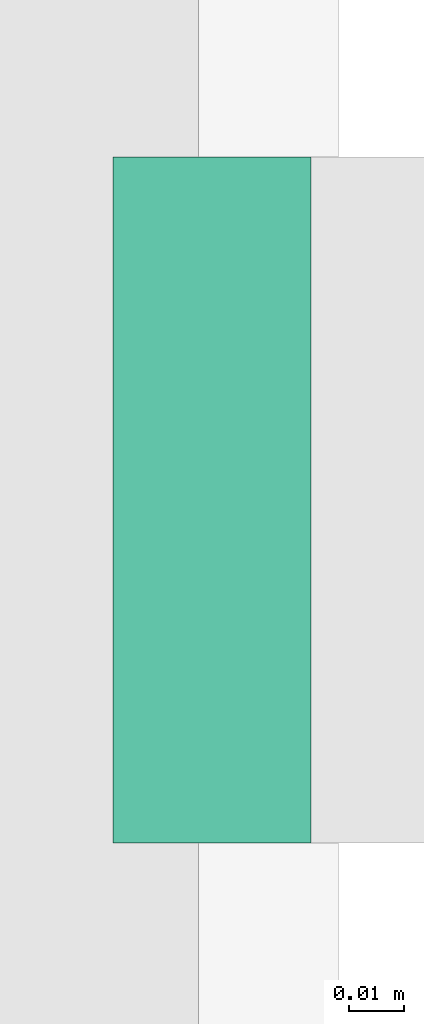
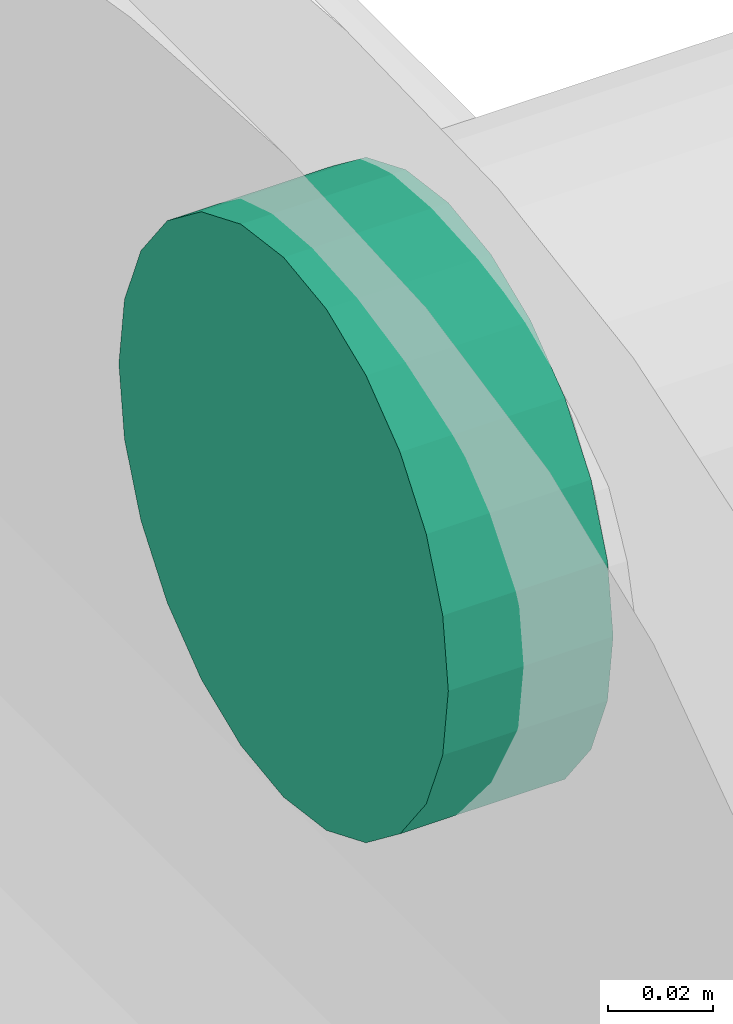
# One storey, part 218 of 337: 1 flow fitting.
"""IFC2X3 building model written with IfcOpenShell, lengths in millimetres."""

from ifc_helpers import new_model, entity, si_unit, converted_unit, derived_unit, direction, frame, origin, place, context, subcontext, project, spatial, faceted_brep, source, transform, mapped, material, type_object, type_shapes, element, save


model = new_model("IFC2X3")

# Units and contexts
model_context = context("Model", 3, precision=0.01, world=origin(), true_north=direction((6.12303176911189e-17, 1.0)))
body_context = subcontext(model_context, "Body", "Model", "MODEL_VIEW")
ifc_project = project(units=[si_unit("LENGTHUNIT", "METRE", prefix="MILLI"), si_unit("AREAUNIT", "SQUARE_METRE"), si_unit("VOLUMEUNIT", "CUBIC_METRE"), converted_unit("PLANEANGLEUNIT", "DEGREE", entity("IfcRatioMeasure", 0.0174532925199433), si_unit("PLANEANGLEUNIT", "RADIAN"), dimensions=[0, 0, 0, 0, 0, 0, 0]), si_unit("MASSUNIT", "GRAM", prefix="KILO"), derived_unit("MASSDENSITYUNIT", [(si_unit("MASSUNIT", "GRAM", prefix="KILO"), 1), (si_unit("LENGTHUNIT", "METRE"), -3)]), derived_unit("MOMENTOFINERTIAUNIT", [(si_unit("LENGTHUNIT", "METRE"), 4)]), si_unit("TIMEUNIT", "SECOND"), si_unit("FREQUENCYUNIT", "HERTZ"), si_unit("THERMODYNAMICTEMPERATUREUNIT", "DEGREE_CELSIUS"), derived_unit("THERMALTRANSMITTANCEUNIT", [(si_unit("MASSUNIT", "GRAM", prefix="KILO"), 1), (si_unit("THERMODYNAMICTEMPERATUREUNIT", "KELVIN"), -1), (si_unit("TIMEUNIT", "SECOND"), -3)]), derived_unit("VOLUMETRICFLOWRATEUNIT", [(si_unit("LENGTHUNIT", "METRE"), 3), (si_unit("TIMEUNIT", "SECOND"), -1)]), derived_unit("MASSFLOWRATEUNIT", [(si_unit("MASSUNIT", "GRAM", prefix="KILO"), 1), (si_unit("TIMEUNIT", "SECOND"), -1)]), derived_unit("ROTATIONALFREQUENCYUNIT", [(si_unit("TIMEUNIT", "SECOND"), -1)]), si_unit("ELECTRICCURRENTUNIT", "AMPERE"), si_unit("ELECTRICVOLTAGEUNIT", "VOLT"), si_unit("POWERUNIT", "WATT"), si_unit("FORCEUNIT", "NEWTON", prefix="KILO"), si_unit("ILLUMINANCEUNIT", "LUX"), si_unit("LUMINOUSFLUXUNIT", "LUMEN"), si_unit("LUMINOUSINTENSITYUNIT", "CANDELA"), derived_unit("USERDEFINED", [(si_unit("MASSUNIT", "GRAM", prefix="KILO"), -1), (si_unit("LENGTHUNIT", "METRE"), -2), (si_unit("TIMEUNIT", "SECOND"), 3), (si_unit("LUMINOUSFLUXUNIT", "LUMEN"), 1)]), derived_unit("LINEARVELOCITYUNIT", [(si_unit("LENGTHUNIT", "METRE"), 1), (si_unit("TIMEUNIT", "SECOND"), -1)]), si_unit("PRESSUREUNIT", "PASCAL"), derived_unit("USERDEFINED", [(si_unit("LENGTHUNIT", "METRE"), -2), (si_unit("MASSUNIT", "GRAM", prefix="KILO"), 1), (si_unit("TIMEUNIT", "SECOND"), -2)]), derived_unit("LINEARFORCEUNIT", [(si_unit("MASSUNIT", "GRAM", prefix="KILO"), 1), (si_unit("LENGTHUNIT", "METRE"), 1), (si_unit("TIMEUNIT", "SECOND"), -2), (si_unit("LENGTHUNIT", "METRE"), -1)]), derived_unit("PLANARFORCEUNIT", [(si_unit("MASSUNIT", "GRAM", prefix="KILO"), 1), (si_unit("LENGTHUNIT", "METRE"), 1), (si_unit("TIMEUNIT", "SECOND"), -2), (si_unit("LENGTHUNIT", "METRE"), -2)])], contexts=[model_context])

# Site, building, storey
site_placement = place(None, origin())
site = spatial("IfcSite", under=ifc_project, at=site_placement, CompositionType="ELEMENT")
building_placement = place(site_placement, origin())
building = spatial("IfcBuilding", under=site, at=building_placement, CompositionType="ELEMENT")
storey_placement = place(building_placement, origin())
storey = spatial("IfcBuildingStorey", under=building, at=storey_placement, CompositionType="ELEMENT", Elevation=0.0)

# Flow fitting
ifc_material = material()
duct_fitting_type = type_object("IfcDuctFittingType", PredefinedType="NOTDEFINED", material=ifc_material)
shared_shape = source(origin(), body_context, "Body", "Brep", [
    faceted_brep([(20.0, 0.0, -62.5), (20.0, 16.18, -60.37), (20.0, 31.25, -54.13), (20.0, 44.19, -44.19), (20.0, 54.13, -31.25), (20.0, 60.37, -16.18), (20.0, 62.5, 0.0), (20.0, 60.37, 16.18), (20.0, 54.13, 31.25), (20.0, 44.19, 44.19), (20.0, 31.25, 54.13), (20.0, 16.18, 60.37), (20.0, 0.0, 62.5), (20.0, -16.18, 60.37), (20.0, -31.25, 54.13), (20.0, -44.19, 44.19), (20.0, -54.13, 31.25), (20.0, -60.37, 16.18), (20.0, -62.5, 0.0), (20.0, -60.37, -16.18), (20.0, -54.13, -31.25), (20.0, -44.19, -44.19), (20.0, -31.25, -54.13), (20.0, -16.18, -60.37), (0.0, 0.0, 62.5), (-16.11, 0.0, 62.5), (-16.11, -16.18, 60.37), (0.0, -16.18, 60.37), (-16.11, -31.25, 54.13), (0.0, -31.25, 54.13), (0.0, -44.19, 44.19), (-16.11, -44.19, 44.19), (0.0, -54.13, 31.25), (-16.11, -54.13, 31.25), (-16.11, -60.37, 16.18), (0.0, -60.37, 16.18), (-16.11, -62.5, 0.0), (0.0, -62.5, 0.0), (-16.11, -60.37, -16.18), (0.0, -60.37, -16.18), (-16.11, -54.13, -31.25), (0.0, -54.13, -31.25), (0.0, -44.19, -44.19), (-16.11, -44.19, -44.19), (0.0, -31.25, -54.13), (-16.11, -31.25, -54.13), (-16.11, -16.18, -60.37), (0.0, -16.18, -60.37), (-16.11, 0.0, -62.5), (0.0, 0.0, -62.5), (-16.11, 16.18, -60.37), (0.0, 16.18, -60.37), (-16.11, 31.25, -54.13), (0.0, 31.25, -54.13), (0.0, 44.19, -44.19), (-16.11, 44.19, -44.19), (0.0, 54.13, -31.25), (-16.11, 54.13, -31.25), (-16.11, 60.37, -16.18), (0.0, 60.37, -16.18), (-16.11, 62.5, 0.0), (0.0, 62.5, 0.0), (-16.11, 60.37, 16.18), (0.0, 60.37, 16.18), (-16.11, 54.13, 31.25), (0.0, 54.13, 31.25), (0.0, 44.19, 44.19), (-16.11, 44.19, 44.19), (0.0, 31.25, 54.13), (-16.11, 31.25, 54.13), (-16.11, 16.18, 60.37), (0.0, 16.18, 60.37)], [[[0, 1, 2, 3, 4, 5, 6, 7, 8, 9, 10, 11, 12, 13, 14, 15, 16, 17, 18, 19, 20, 21, 22, 23]], [[13, 12, 24, 25, 26, 27]], [[14, 13, 27, 26, 28, 29]], [[30, 15, 14, 29, 28, 31]], [[17, 16, 32, 33, 34, 35]], [[18, 17, 35, 34, 36, 37]], [[32, 16, 15, 30, 31, 33]], [[19, 18, 37, 36, 38, 39]], [[20, 19, 39, 38, 40, 41]], [[42, 21, 20, 41, 40, 43]], [[23, 22, 44, 45, 46, 47]], [[0, 23, 47, 46, 48, 49]], [[44, 22, 21, 42, 43, 45]], [[1, 0, 49, 48, 50, 51]], [[2, 1, 51, 50, 52, 53]], [[54, 3, 2, 53, 52, 55]], [[5, 4, 56, 57, 58, 59]], [[6, 5, 59, 58, 60, 61]], [[56, 4, 3, 54, 55, 57]], [[7, 6, 61, 60, 62, 63]], [[8, 7, 63, 62, 64, 65]], [[66, 9, 8, 65, 64, 67]], [[11, 10, 68, 69, 70, 71]], [[12, 11, 71, 70, 25, 24]], [[68, 10, 9, 66, 67, 69]], [[46, 45, 43, 40, 38, 36, 34, 33, 31, 28, 26, 25, 70, 69, 67, 64, 62, 60, 58, 57, 55, 52, 50, 48]]]),
])
type_shapes(duct_fitting_type, [shared_shape])
flow_fitting_placement = place(storey_placement, frame((66498.97, 7113.07, 3500.0), z_axis=(0.0, 0.0, -1.0), x_axis=(1.0, 0.0, 0.0)))
element("IfcFlowFitting", 1, at=flow_fitting_placement, inside=storey, type_object=duct_fitting_type, material=ifc_material, context=body_context, shape_type="MappedRepresentation", body=[
    mapped(shared_shape, transform((0.0, 0.0, 0.0), scale=1.0)),
])

save(model, "model.ifc")
